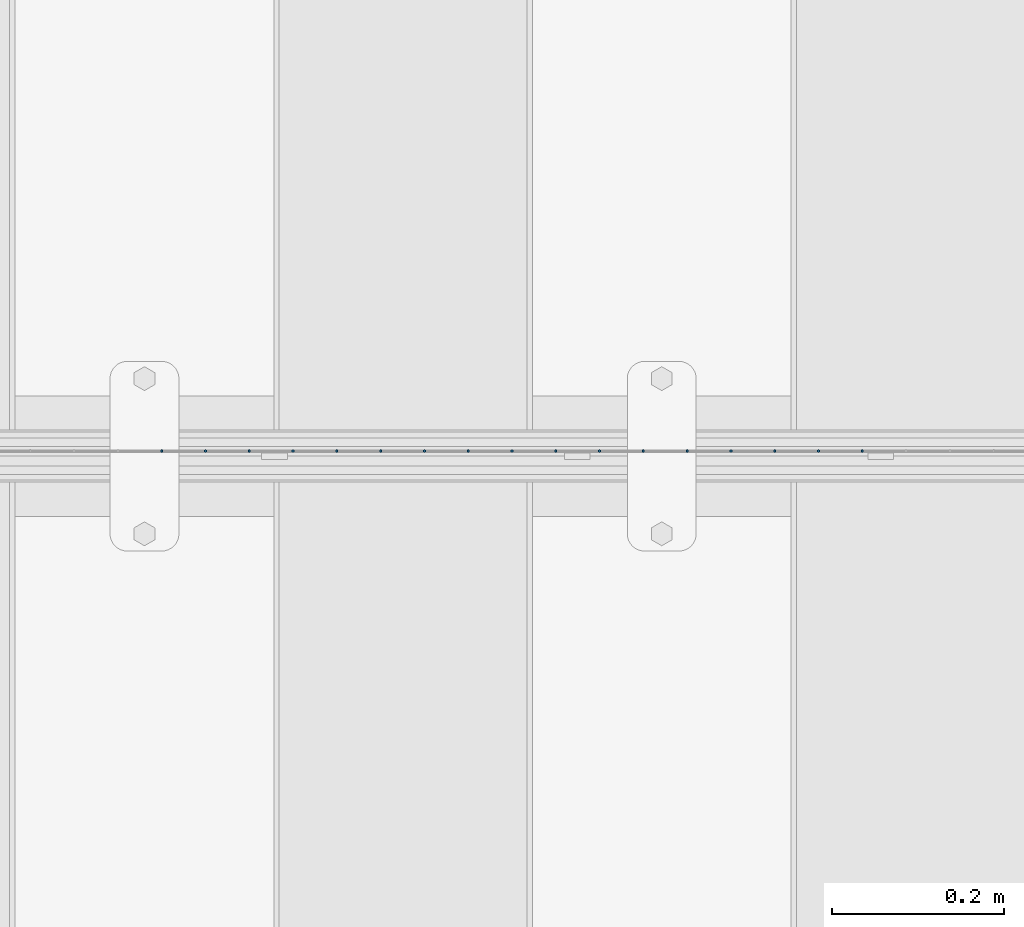
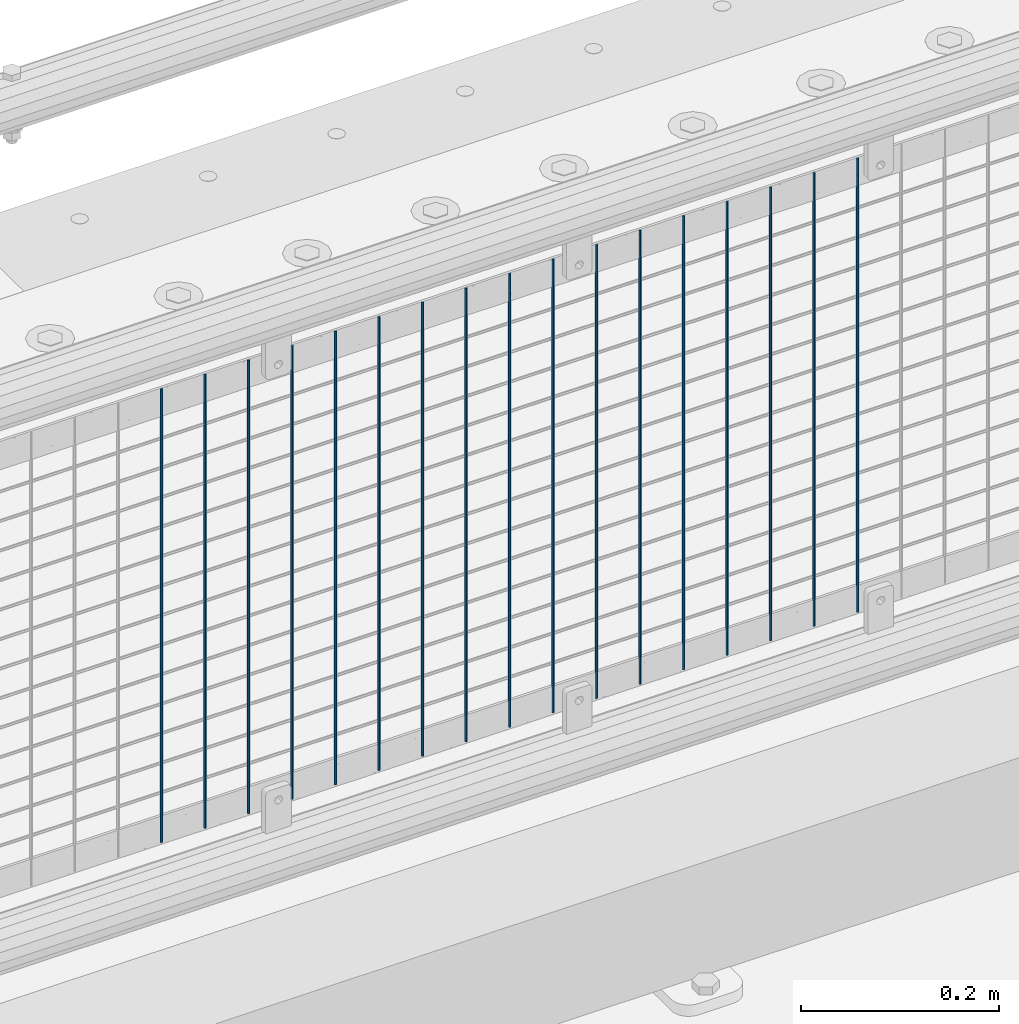
# One storey, part 82 of 242: 17 columns.
"""IFC2X3 building model written with IfcOpenShell, lengths in millimetres."""

from ifc_helpers import new_model, si_unit, frame, origin_with_axes, place, context, subcontext, project, spatial, faceted_brep, material, type_object, element, save


model = new_model("IFC2X3")

# Units and contexts
model_context = context("Model", 3, precision=1e-05, world=origin_with_axes())
body_context = subcontext(model_context, "Body", "Model", "MODEL_VIEW")
ifc_project = project(units=[si_unit("LENGTHUNIT", "METRE", prefix="MILLI"), si_unit("AREAUNIT", "SQUARE_METRE"), si_unit("VOLUMEUNIT", "CUBIC_METRE"), si_unit("MASSUNIT", "GRAM", prefix="KILO"), si_unit("TIMEUNIT", "SECOND"), si_unit("PLANEANGLEUNIT", "RADIAN"), si_unit("SOLIDANGLEUNIT", "STERADIAN"), si_unit("THERMODYNAMICTEMPERATUREUNIT", "DEGREE_CELSIUS"), si_unit("LUMINOUSINTENSITYUNIT", "LUMEN")], contexts=[model_context])

# Site, building, storey
site_placement = place(None, origin_with_axes())
site = spatial("IfcSite", under=ifc_project, at=site_placement, CompositionType="ELEMENT")
building_placement = place(site_placement, origin_with_axes())
building = spatial("IfcBuilding", under=site, at=building_placement, Name="Standard", CompositionType="ELEMENT")
storey_placement = place(building_placement, origin_with_axes())
storey = spatial("IfcBuildingStorey", under=building, at=storey_placement, Name="Undefined", CompositionType="ELEMENT", Elevation=0.0)

# Columns
ifc_material = material(Name="Misc_Undefined")
column_type = type_object("IfcColumnType", Name="D3", PredefinedType="NOTDEFINED")
for number, where, z_axis, x_axis in (
    (1, (-32517.347, -19329.5, 353.02), (-1.0, 0.0, 0.0), (0.0, 0.0, 1.0)),
    (2, (-32568.14, -19329.5, 353.02), (-1.0, 0.0, 0.0), (0.0, 0.0, 1.0)),
    (3, (-32618.933, -19329.5, 353.02), (-1.0, 0.0, 0.0), (0.0, 0.0, 1.0)),
    (4, (-32669.726, -19329.5, 353.02), (-1.0, 0.0, 0.0), (0.0, 0.0, 1.0)),
    (5, (-32720.519, -19329.5, 353.02), (-1.0, 0.0, 0.0), (0.0, 0.0, 1.0)),
    (6, (-32771.312, -19329.5, 353.02), (-1.0, 0.0, 0.0), (0.0, 0.0, 1.0)),
    (7, (-32822.105, -19329.5, 353.02), (-1.0, 0.0, 0.0), (0.0, 0.0, 1.0)),
    (8, (-32872.898, -19329.5, 353.02), (-1.0, 0.0, 0.0), (0.0, 0.0, 1.0)),
    (9, (-32923.691, -19329.5, 353.02), (-1.0, 0.0, 0.0), (0.0, 0.0, 1.0)),
    (10, (-32974.484, -19329.5, 353.02), (-1.0, 0.0, 0.0), (0.0, 0.0, 1.0)),
    (11, (-33025.277, -19329.5, 353.02), (-1.0, 0.0, 0.0), (0.0, 0.0, 1.0)),
    (12, (-33076.07, -19329.5, 353.02), (-1.0, 0.0, 0.0), (0.0, 0.0, 1.0)),
    (13, (-33126.863, -19329.5, 353.02), (-1.0, 0.0, 0.0), (0.0, 0.0, 1.0)),
    (14, (-33177.656, -19329.5, 353.02), (-1.0, 0.0, 0.0), (0.0, 0.0, 1.0)),
    (15, (-33228.449, -19329.5, 353.02), (-1.0, 0.0, 0.0), (0.0, 0.0, 1.0)),
    (16, (-33279.242, -19329.5, 353.02), (-1.0, 0.0, 0.0), (0.0, 0.0, 1.0)),
    (17, (-33330.035, -19329.5, 353.02), (-1.0, 0.0, 0.0), (0.0, 0.0, 1.0)),
):
    element("IfcColumn", number, at=place(storey_placement, frame(where, z_axis=z_axis, x_axis=x_axis)), inside=storey, type_object=column_type, material=ifc_material, ObjectType="D3", context=body_context, shape_type="Brep", body=[
        faceted_brep([(0.0, -1.50000000000364, 0.0), (-3.63797880709171e-12, -0.750000000003638, -1.29903810567669), (560.0, -0.75, -1.29903810567703), (560.0, -1.5, 0.0), (0.0, 0.749999999996362, -1.29903810567669), (560.0, 0.75, -1.29903810567703), (-3.63797880709171e-12, 1.49999999999636, 0.0), (560.0, 1.5, 0.0), (0.0, 0.749999999996362, 1.29903810567669), (560.0, 0.75, 1.29903810567703), (-3.63797880709171e-12, -0.750000000003638, 1.29903810567669), (560.0, -0.75, 1.29903810567703)], [[[0, 1, 2, 3]], [[1, 4, 5, 2]], [[4, 6, 7, 5]], [[6, 8, 9, 7]], [[8, 10, 11, 9]], [[10, 0, 3, 11]], [[5, 7, 9, 11, 3, 2]], [[10, 8, 6, 4, 1, 0]]]),
    ])

save(model, "model.ifc")
